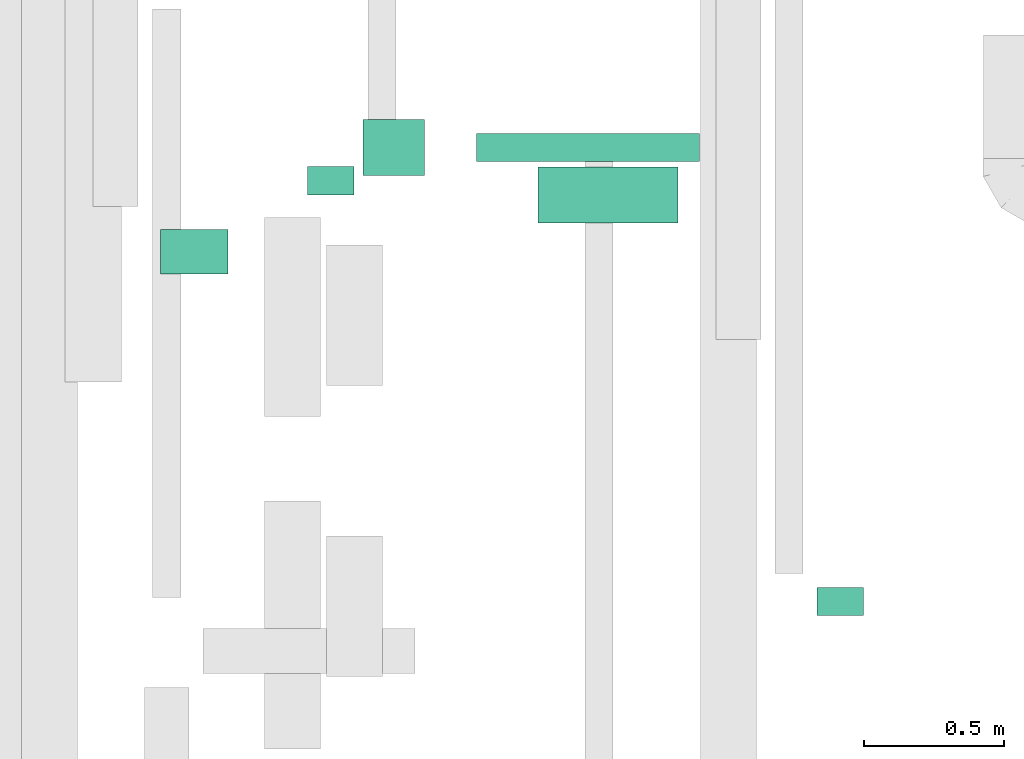
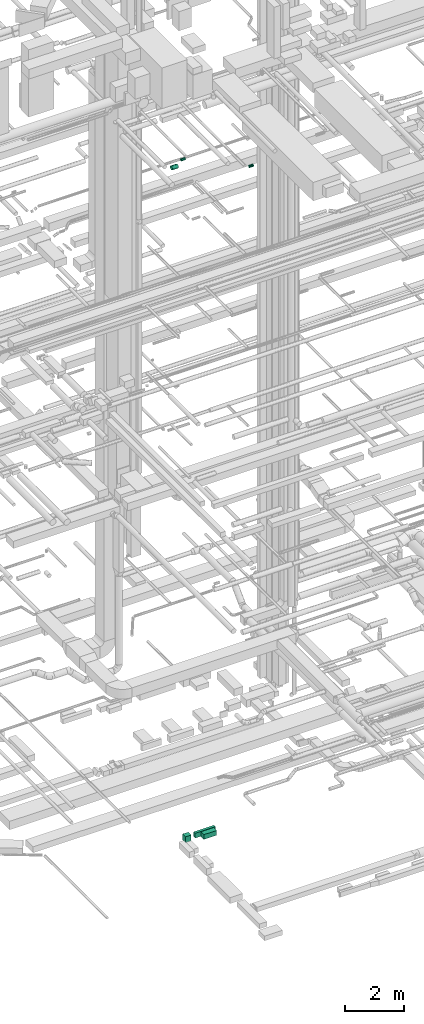
# One storey, part 118 of 337: 6 flow segments.
"""IFC2X3 building model written with IfcOpenShell, lengths in millimetres."""

from ifc_helpers import new_model, entity, si_unit, converted_unit, derived_unit, direction, frame, origin, origin_2d_with_axis, place, context, subcontext, project, spatial, rectangle, circle, extrude, type_object, element, save


model = new_model("IFC2X3")

# Units and contexts
model_context = context("Model", 3, precision=0.01, world=origin(), true_north=direction((6.12303176911189e-17, 1.0)))
body_context = subcontext(model_context, "Body", "Model", "MODEL_VIEW")
ifc_project = project(units=[si_unit("LENGTHUNIT", "METRE", prefix="MILLI"), si_unit("AREAUNIT", "SQUARE_METRE"), si_unit("VOLUMEUNIT", "CUBIC_METRE"), converted_unit("PLANEANGLEUNIT", "DEGREE", entity("IfcRatioMeasure", 0.0174532925199433), si_unit("PLANEANGLEUNIT", "RADIAN"), dimensions=[0, 0, 0, 0, 0, 0, 0]), si_unit("MASSUNIT", "GRAM", prefix="KILO"), derived_unit("MASSDENSITYUNIT", [(si_unit("MASSUNIT", "GRAM", prefix="KILO"), 1), (si_unit("LENGTHUNIT", "METRE"), -3)]), derived_unit("MOMENTOFINERTIAUNIT", [(si_unit("LENGTHUNIT", "METRE"), 4)]), si_unit("TIMEUNIT", "SECOND"), si_unit("FREQUENCYUNIT", "HERTZ"), si_unit("THERMODYNAMICTEMPERATUREUNIT", "DEGREE_CELSIUS"), derived_unit("THERMALTRANSMITTANCEUNIT", [(si_unit("MASSUNIT", "GRAM", prefix="KILO"), 1), (si_unit("THERMODYNAMICTEMPERATUREUNIT", "KELVIN"), -1), (si_unit("TIMEUNIT", "SECOND"), -3)]), derived_unit("VOLUMETRICFLOWRATEUNIT", [(si_unit("LENGTHUNIT", "METRE"), 3), (si_unit("TIMEUNIT", "SECOND"), -1)]), derived_unit("MASSFLOWRATEUNIT", [(si_unit("MASSUNIT", "GRAM", prefix="KILO"), 1), (si_unit("TIMEUNIT", "SECOND"), -1)]), derived_unit("ROTATIONALFREQUENCYUNIT", [(si_unit("TIMEUNIT", "SECOND"), -1)]), si_unit("ELECTRICCURRENTUNIT", "AMPERE"), si_unit("ELECTRICVOLTAGEUNIT", "VOLT"), si_unit("POWERUNIT", "WATT"), si_unit("FORCEUNIT", "NEWTON", prefix="KILO"), si_unit("ILLUMINANCEUNIT", "LUX"), si_unit("LUMINOUSFLUXUNIT", "LUMEN"), si_unit("LUMINOUSINTENSITYUNIT", "CANDELA"), derived_unit("USERDEFINED", [(si_unit("MASSUNIT", "GRAM", prefix="KILO"), -1), (si_unit("LENGTHUNIT", "METRE"), -2), (si_unit("TIMEUNIT", "SECOND"), 3), (si_unit("LUMINOUSFLUXUNIT", "LUMEN"), 1)]), derived_unit("LINEARVELOCITYUNIT", [(si_unit("LENGTHUNIT", "METRE"), 1), (si_unit("TIMEUNIT", "SECOND"), -1)]), si_unit("PRESSUREUNIT", "PASCAL"), derived_unit("USERDEFINED", [(si_unit("LENGTHUNIT", "METRE"), -2), (si_unit("MASSUNIT", "GRAM", prefix="KILO"), 1), (si_unit("TIMEUNIT", "SECOND"), -2)]), derived_unit("LINEARFORCEUNIT", [(si_unit("MASSUNIT", "GRAM", prefix="KILO"), 1), (si_unit("LENGTHUNIT", "METRE"), 1), (si_unit("TIMEUNIT", "SECOND"), -2), (si_unit("LENGTHUNIT", "METRE"), -1)]), derived_unit("PLANARFORCEUNIT", [(si_unit("MASSUNIT", "GRAM", prefix="KILO"), 1), (si_unit("LENGTHUNIT", "METRE"), 1), (si_unit("TIMEUNIT", "SECOND"), -2), (si_unit("LENGTHUNIT", "METRE"), -2)])], contexts=[model_context])

# Site, building, storey
site_placement = place(None, origin())
site = spatial("IfcSite", under=ifc_project, at=site_placement, CompositionType="ELEMENT")
building_placement = place(site_placement, origin())
building = spatial("IfcBuilding", under=site, at=building_placement, CompositionType="ELEMENT")
storey_placement = place(building_placement, origin())
storey = spatial("IfcBuildingStorey", under=building, at=storey_placement, CompositionType="ELEMENT", Elevation=0.0)

# Flow segments
duct_segment_type_1 = type_object("IfcDuctSegmentType", PredefinedType="NOTDEFINED")
flow_segment_1_placement = place(storey_placement, frame((23994.4, 6075.53, -1025.0)))
element("IfcFlowSegment", 1, at=flow_segment_1_placement, inside=storey, type_object=duct_segment_type_1, context=body_context, shape_type="SweptSolid", body=[
    extrude(rectangle(XDim=219.368499250224, YDim=200.0, at=origin_2d_with_axis()), frame((109.68, 100.0, 0.0)), (0.0, 0.0, 1.0), 250.0),
])
flow_segment_2_placement = place(storey_placement, frame((24400.37, 6125.53, -1000.0)))
element("IfcFlowSegment", 2, at=flow_segment_2_placement, inside=storey, type_object=duct_segment_type_1, context=body_context, shape_type="SweptSolid", body=[
    extrude(rectangle(XDim=794.03150074978, YDim=100.0, at=origin_2d_with_axis()), frame((397.02, 50.0, 0.0)), (0.0, 0.0, 1.0), 200.0),
])
flow_segment_3_placement = place(storey_placement, frame((24618.61, 5905.53, -1000.0)))
element("IfcFlowSegment", 3, at=flow_segment_3_placement, inside=storey, type_object=duct_segment_type_1, context=body_context, shape_type="SweptSolid", body=[
    extrude(rectangle(XDim=200.0, YDim=499.999999999999, at=origin_2d_with_axis()), frame((250.0, 100.0, 0.0), z_axis=(0.0, 0.0, 1.0), x_axis=(0.0, -1.0, 0.0)), (0.0, 0.0, 1.0), 200.0),
])
duct_segment_type_2 = type_object("IfcDuctSegmentType", PredefinedType="NOTDEFINED")
flow_segment_4_placement = place(storey_placement, frame((23273.85, 5722.41, 27418.4)))
element("IfcFlowSegment", 4, at=flow_segment_4_placement, inside=storey, type_object=duct_segment_type_2, context=body_context, shape_type="SweptSolid", body=[
    extrude(circle(Radius=80.0, at=origin_2d_with_axis()), frame((0.0, 81.6, 81.6), z_axis=(1.0, 0.0, 0.0), x_axis=(0.0, -1.0, 0.0)), (0.0, 0.0, 1.0), 240.000000000002),
])
flow_segment_5_placement = place(storey_placement, frame((23797.93, 6004.91, 27448.4)))
element("IfcFlowSegment", 5, at=flow_segment_5_placement, inside=storey, type_object=duct_segment_type_2, context=body_context, shape_type="SweptSolid", body=[
    extrude(circle(Radius=50.0, at=origin_2d_with_axis()), frame((0.0, 51.6, 51.6), z_axis=(1.0, 0.0, 0.0), x_axis=(0.0, 1.0, 0.0)), (0.0, 0.0, 1.0), 165.000000000019),
])
flow_segment_6_placement = place(storey_placement, frame((25613.69, 4504.91, 27448.4)))
element("IfcFlowSegment", 6, at=flow_segment_6_placement, inside=storey, type_object=duct_segment_type_2, context=body_context, shape_type="SweptSolid", body=[
    extrude(circle(Radius=50.0, at=origin_2d_with_axis()), frame((0.0, 51.6, 51.6), z_axis=(1.0, 0.0, 0.0), x_axis=(0.0, -1.0, 0.0)), (0.0, 0.0, 1.0), 165.000000000032),
])

save(model, "model.ifc")
